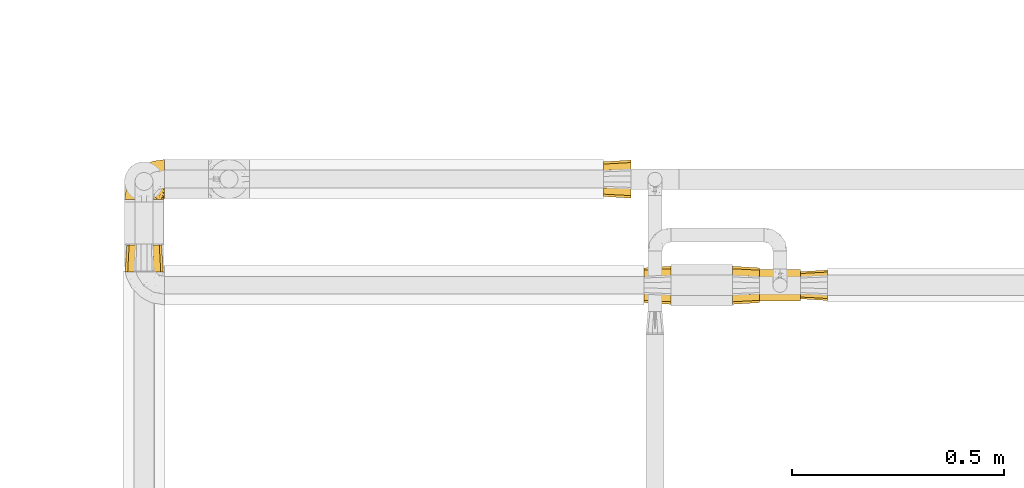
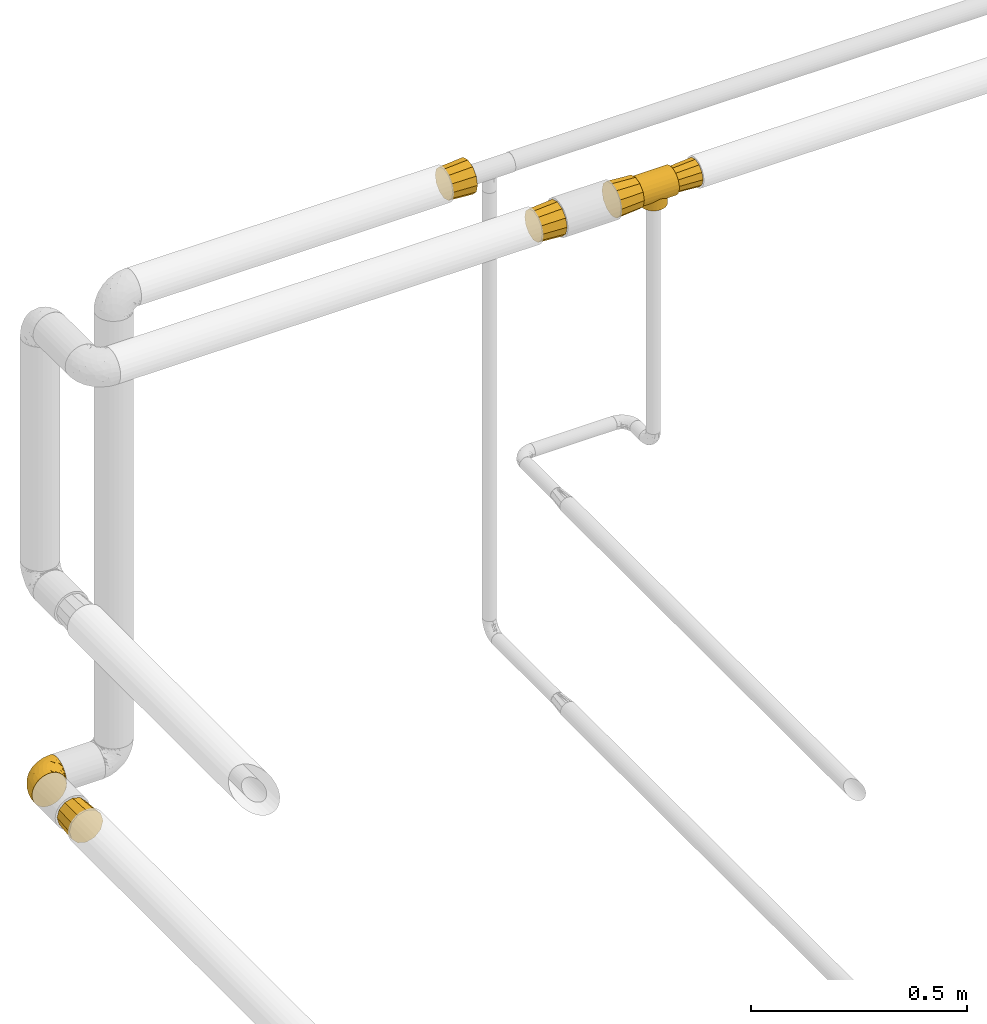
# One storey, part 133 of 827: 7 coverings.
"""IFC2X3 building model written with IfcOpenShell, lengths in millimetres."""

from ifc_helpers import new_model, entity, si_unit, converted_unit, derived_unit, direction, frame, origin, place, context, subcontext, project, spatial, faceted_brep, element, save


model = new_model("IFC2X3")

# Units and contexts
model_context = context("Model", 3, precision=0.01, world=origin(), true_north=direction((6.12303176911189e-17, 1.0)))
body_context = subcontext(model_context, "Body", "Model", "MODEL_VIEW")
ifc_project = project(units=[si_unit("LENGTHUNIT", "METRE", prefix="MILLI"), si_unit("AREAUNIT", "SQUARE_METRE"), si_unit("VOLUMEUNIT", "CUBIC_METRE"), converted_unit("PLANEANGLEUNIT", "DEGREE", entity("IfcRatioMeasure", 0.0174532925199433), si_unit("PLANEANGLEUNIT", "RADIAN"), dimensions=[0, 0, 0, 0, 0, 0, 0]), si_unit("MASSUNIT", "GRAM", prefix="KILO"), derived_unit("MASSDENSITYUNIT", [(si_unit("MASSUNIT", "GRAM", prefix="KILO"), 1), (si_unit("LENGTHUNIT", "METRE"), -3)]), derived_unit("MOMENTOFINERTIAUNIT", [(si_unit("LENGTHUNIT", "METRE"), 4)]), si_unit("TIMEUNIT", "SECOND"), si_unit("FREQUENCYUNIT", "HERTZ"), si_unit("THERMODYNAMICTEMPERATUREUNIT", "DEGREE_CELSIUS"), derived_unit("THERMALTRANSMITTANCEUNIT", [(si_unit("MASSUNIT", "GRAM", prefix="KILO"), 1), (si_unit("THERMODYNAMICTEMPERATUREUNIT", "KELVIN"), -1), (si_unit("TIMEUNIT", "SECOND"), -3)]), derived_unit("VOLUMETRICFLOWRATEUNIT", [(si_unit("LENGTHUNIT", "METRE"), 3), (si_unit("TIMEUNIT", "SECOND"), -1)]), derived_unit("MASSFLOWRATEUNIT", [(si_unit("MASSUNIT", "GRAM", prefix="KILO"), 1), (si_unit("TIMEUNIT", "SECOND"), -1)]), derived_unit("ROTATIONALFREQUENCYUNIT", [(si_unit("TIMEUNIT", "SECOND"), -1)]), si_unit("ELECTRICCURRENTUNIT", "AMPERE"), si_unit("ELECTRICVOLTAGEUNIT", "VOLT"), si_unit("POWERUNIT", "WATT"), si_unit("FORCEUNIT", "NEWTON", prefix="KILO"), si_unit("ILLUMINANCEUNIT", "LUX"), si_unit("LUMINOUSFLUXUNIT", "LUMEN"), si_unit("LUMINOUSINTENSITYUNIT", "CANDELA"), derived_unit("USERDEFINED", [(si_unit("MASSUNIT", "GRAM", prefix="KILO"), -1), (si_unit("LENGTHUNIT", "METRE"), -2), (si_unit("TIMEUNIT", "SECOND"), 3), (si_unit("LUMINOUSFLUXUNIT", "LUMEN"), 1)]), derived_unit("LINEARVELOCITYUNIT", [(si_unit("LENGTHUNIT", "METRE"), 1), (si_unit("TIMEUNIT", "SECOND"), -1)]), si_unit("PRESSUREUNIT", "PASCAL"), derived_unit("USERDEFINED", [(si_unit("LENGTHUNIT", "METRE"), -2), (si_unit("MASSUNIT", "GRAM", prefix="KILO"), 1), (si_unit("TIMEUNIT", "SECOND"), -2)]), derived_unit("LINEARFORCEUNIT", [(si_unit("MASSUNIT", "GRAM", prefix="KILO"), 1), (si_unit("LENGTHUNIT", "METRE"), 1), (si_unit("TIMEUNIT", "SECOND"), -2), (si_unit("LENGTHUNIT", "METRE"), -1)]), derived_unit("PLANARFORCEUNIT", [(si_unit("MASSUNIT", "GRAM", prefix="KILO"), 1), (si_unit("LENGTHUNIT", "METRE"), 1), (si_unit("TIMEUNIT", "SECOND"), -2), (si_unit("LENGTHUNIT", "METRE"), -2)])], contexts=[model_context])

# Site, building, storey
site_placement = place(None, origin())
site = spatial("IfcSite", under=ifc_project, at=site_placement, CompositionType="ELEMENT")
building_placement = place(site_placement, origin())
building = spatial("IfcBuilding", under=site, at=building_placement, CompositionType="ELEMENT")
storey_placement = place(building_placement, frame((0.0, 0.0, 28200.0)))
storey = spatial("IfcBuildingStorey", under=building, at=storey_placement, Name="08", CompositionType="ELEMENT", Elevation=28200.0)

# Coverings
covering_1_placement = place(storey_placement, frame((13457.95, 18724.18, 2952.0)))
element("IfcCovering", 1, at=covering_1_placement, inside=storey, Name=":ADSK_", ObjectType=":ADSK_", PredefinedType="INSULATION", context=body_context, shape_type="Brep", body=[
    faceted_brep([(0.0, 6.58, 66.6), (0.0, 12.49, 74.3), (0.0, 20.2, 80.22), (0.0, 29.17, 83.93), (0.0, 38.8, 85.2), (0.0, 48.42, 83.93), (0.0, 57.4, 80.22), (0.0, 65.1, 74.3), (0.0, 71.01, 66.6), (0.0, 74.73, 57.63), (0.0, 76.0, 48.0), (0.0, 74.73, 38.37), (0.0, 71.01, 29.4), (0.0, 68.06, 25.55), (0.0, 65.1, 21.7), (0.0, 61.25, 18.74), (0.0, 57.4, 15.78), (0.0, 52.91, 13.93), (0.0, 50.67, 13.0), (0.0, 48.42, 12.07), (0.0, 46.02, 11.75), (0.0, 43.61, 11.43), (0.0, 38.8, 10.8), (0.0, 33.98, 11.43), (0.0, 31.57, 11.75), (0.0, 29.17, 12.07), (0.0, 26.92, 13.0), (0.0, 24.68, 13.93), (0.0, 20.2, 15.78), (0.0, 16.34, 18.74), (0.0, 12.49, 21.7), (0.0, 9.54, 25.55), (0.0, 6.58, 29.4), (0.0, 2.86, 38.37), (0.0, 1.6, 48.0), (0.0, 2.86, 57.63), (96.0, 74.73, 57.63), (96.0, 71.01, 66.6), (96.0, 65.1, 74.3), (96.0, 57.4, 80.22), (96.0, 48.42, 83.93), (96.0, 38.8, 85.2), (96.0, 29.17, 83.93), (96.0, 20.2, 80.22), (96.0, 12.49, 74.3), (96.0, 6.58, 66.6), (96.0, 2.86, 57.63), (96.0, 1.6, 48.0), (96.0, 2.86, 38.37), (96.0, 6.58, 29.4), (96.0, 9.54, 25.55), (96.0, 12.49, 21.7), (96.0, 16.34, 18.74), (96.0, 20.2, 15.78), (96.0, 24.68, 13.93), (96.0, 26.92, 13.0), (96.0, 29.17, 12.07), (96.0, 31.57, 11.75), (96.0, 33.98, 11.43), (96.0, 38.8, 10.8), (96.0, 43.61, 11.43), (96.0, 46.02, 11.75), (96.0, 48.42, 12.07), (96.0, 50.67, 13.0), (96.0, 52.91, 13.93), (96.0, 57.4, 15.78), (96.0, 61.25, 18.74), (96.0, 65.1, 21.7), (96.0, 68.06, 25.55), (96.0, 71.01, 29.4), (96.0, 74.73, 38.37), (96.0, 76.0, 48.0), (48.0, 71.65, 30.54), (68.25, 64.67, 21.27), (62.44, 68.3, 25.35), (17.44, 50.24, 12.8), (18.78, 53.81, 13.96), (55.72, 70.72, 28.91), (33.56, 68.3, 25.35), (16.11, 46.67, 11.64), (15.63, 42.73, 11.22), (40.28, 70.72, 28.91), (15.15, 38.8, 10.8), (80.85, 38.8, 10.8), (80.37, 42.73, 11.22), (27.75, 64.67, 21.27), (22.78, 59.84, 17.33), (73.22, 59.84, 17.33), (77.22, 53.81, 13.96), (75.22, 56.83, 15.65), (78.56, 50.24, 12.8), (79.89, 46.67, 11.64), (20.78, 56.83, 15.65), (80.37, 34.86, 11.22), (79.89, 30.92, 11.64), (16.11, 30.92, 11.64), (77.22, 23.78, 13.96), (73.22, 17.75, 17.33), (75.22, 20.77, 15.65), (68.25, 12.93, 21.27), (78.56, 27.35, 12.8), (15.63, 34.86, 11.22), (62.44, 9.29, 25.35), (20.78, 20.77, 15.65), (22.78, 17.75, 17.33), (18.78, 23.78, 13.96), (17.44, 27.35, 12.8), (48.0, 5.95, 30.54), (55.72, 6.87, 28.91), (33.56, 9.29, 25.35), (27.75, 12.93, 21.27), (40.28, 6.87, 28.91), (71.23, 62.02, 0.0), (76.45, 55.22, 0.0), (79.73, 47.3, 0.0), (80.85, 38.8, 0.0), (79.73, 30.29, 0.0), (76.45, 22.37, 0.0), (71.23, 15.57, 0.0), (64.42, 10.35, 0.0), (56.5, 7.06, 0.0), (48.0, 5.95, 0.0), (39.5, 7.06, 0.0), (31.57, 10.35, 0.0), (24.77, 15.57, 0.0), (19.55, 22.37, 0.0), (16.27, 30.29, 0.0), (15.15, 38.8, 0.0), (16.27, 47.3, 0.0), (19.55, 55.22, 0.0), (24.77, 62.02, 0.0), (31.57, 67.24, 0.0), (39.5, 70.53, 0.0), (48.0, 71.65, 0.0), (56.5, 70.53, 0.0), (64.42, 67.24, 0.0)], [[[0, 1, 2, 3, 4, 5, 6, 7, 8, 9, 10, 11, 12, 13, 14, 15, 16, 17, 18, 19, 20, 21, 22, 23, 24, 25, 26, 27, 28, 29, 30, 31, 32, 33, 34, 35]], [[36, 37, 38, 39, 40, 41, 42, 43, 44, 45, 46, 47, 48, 49, 50, 51, 52, 53, 54, 55, 56, 57, 58, 59, 60, 61, 62, 63, 64, 65, 66, 67, 68, 69, 70, 71]], [[39, 38, 7, 6]], [[4, 41, 40, 5]], [[40, 39, 6, 5]], [[8, 37, 36, 9]], [[9, 36, 71, 10]], [[7, 38, 37, 8]], [[70, 11, 10, 71]], [[69, 72, 70]], [[67, 73, 74]], [[67, 66, 73]], [[75, 17, 76]], [[77, 69, 74]], [[78, 14, 13, 12]], [[74, 69, 68, 67]], [[77, 72, 69]], [[11, 70, 72]], [[11, 72, 12]], [[21, 79, 80]], [[81, 78, 12]], [[22, 80, 82]], [[83, 84, 59]], [[14, 78, 85]], [[81, 12, 72]], [[86, 16, 15]], [[59, 84, 60]], [[75, 19, 18, 17]], [[87, 65, 88, 89]], [[73, 66, 87]], [[63, 62, 90, 64]], [[91, 62, 61, 60]], [[91, 60, 84]], [[90, 88, 64]], [[15, 14, 85]], [[88, 65, 64]], [[16, 76, 17]], [[76, 16, 86, 92]], [[62, 91, 90]], [[15, 85, 86]], [[22, 21, 80]], [[20, 19, 79, 21]], [[79, 19, 75]], [[87, 66, 65]], [[58, 93, 59]], [[94, 58, 57, 56]], [[95, 25, 24, 23]], [[54, 53, 96]], [[97, 53, 52]], [[98, 96, 53, 97]], [[51, 99, 52]], [[56, 100, 94]], [[59, 93, 83]], [[101, 22, 82]], [[95, 23, 101]], [[102, 51, 50, 49]], [[100, 56, 55, 54]], [[103, 104, 28, 105]], [[100, 54, 96]], [[22, 101, 23]], [[25, 106, 27, 26]], [[104, 29, 28]], [[27, 106, 105]], [[58, 94, 93]], [[99, 51, 102]], [[99, 97, 52]], [[25, 95, 106]], [[107, 49, 48]], [[107, 108, 49]], [[49, 108, 102]], [[48, 47, 34, 33]], [[105, 28, 27]], [[30, 109, 32, 31]], [[110, 29, 104]], [[30, 29, 110]], [[30, 110, 109]], [[109, 111, 32]], [[32, 107, 33]], [[107, 32, 111]], [[33, 107, 48]], [[35, 46, 45, 0]], [[0, 45, 44, 1]], [[47, 46, 35, 34]], [[2, 43, 42, 3]], [[3, 42, 41, 4]], [[1, 44, 43, 2]], [[112, 113, 114, 115, 116, 117, 118, 119, 120, 121, 122, 123, 124, 125, 126, 127, 128, 129, 130, 131, 132, 133, 134, 135]], [[91, 115, 114]], [[88, 114, 113]], [[115, 91, 84, 83]], [[113, 87, 89, 88]], [[114, 88, 90, 91]], [[113, 112, 87]], [[112, 135, 73]], [[135, 134, 74]], [[77, 134, 133]], [[73, 135, 74]], [[77, 74, 134]], [[72, 77, 133]], [[112, 73, 87]], [[81, 133, 132]], [[78, 132, 131]], [[72, 133, 81]], [[81, 132, 78]], [[131, 85, 78]], [[131, 130, 85]], [[130, 129, 86]], [[129, 128, 76]], [[79, 128, 127]], [[129, 76, 92, 86]], [[127, 82, 80, 79]], [[128, 79, 75, 76]], [[130, 86, 85]], [[95, 127, 126]], [[105, 126, 125]], [[127, 95, 101, 82]], [[125, 104, 103, 105]], [[126, 105, 106, 95]], [[125, 124, 104]], [[110, 124, 123]], [[122, 121, 111]], [[109, 123, 122]], [[110, 123, 109]], [[111, 109, 122]], [[107, 111, 121]], [[124, 110, 104]], [[108, 121, 120]], [[102, 120, 119]], [[107, 121, 108]], [[108, 120, 102]], [[119, 99, 102]], [[119, 118, 99]], [[97, 118, 117]], [[117, 116, 96]], [[115, 94, 116]], [[117, 96, 98, 97]], [[115, 83, 93, 94]], [[116, 94, 100, 96]], [[118, 97, 99]]]),
])
covering_2_placement = place(storey_placement, frame((13553.95, 18725.38, 2962.4)))
element("IfcCovering", 2, at=covering_2_placement, inside=storey, Name=":ADSK_", ObjectType=":ADSK_", PredefinedType="INSULATION", context=body_context, shape_type="Brep", body=[
    faceted_brep([(64.0, 55.6, 68.77), (64.0, 47.12, 71.04), (64.0, 37.6, 73.6), (64.0, 28.07, 71.04), (64.0, 19.6, 68.77), (64.0, 13.01, 62.18), (64.0, 6.42, 55.6), (64.0, 4.15, 47.12), (64.0, 1.6, 37.6), (64.0, 4.15, 28.07), (64.0, 6.42, 19.6), (64.0, 13.01, 13.01), (64.0, 19.6, 6.42), (64.0, 28.07, 4.15), (64.0, 37.6, 1.6), (64.0, 47.12, 4.15), (64.0, 55.6, 6.42), (64.0, 62.18, 13.01), (64.0, 68.77, 19.6), (64.0, 71.04, 28.07), (64.0, 73.6, 37.6), (64.0, 71.04, 47.12), (64.0, 68.77, 55.6), (64.0, 62.18, 62.18), (0.0, 69.6, 37.6), (0.0, 67.45, 29.6), (0.0, 65.31, 21.6), (0.0, 59.45, 15.74), (0.0, 53.6, 9.88), (0.0, 45.6, 7.74), (0.0, 37.6, 5.6), (0.0, 29.6, 7.74), (0.0, 21.6, 9.88), (0.0, 15.74, 15.74), (0.0, 9.88, 21.6), (0.0, 7.74, 29.6), (0.0, 5.6, 37.6), (0.0, 7.74, 45.6), (0.0, 9.88, 53.6), (0.0, 15.74, 59.45), (0.0, 21.6, 65.31), (0.0, 29.6, 67.45), (0.0, 37.6, 69.6), (0.0, 45.6, 67.45), (0.0, 53.6, 65.31), (0.0, 59.45, 59.45), (0.0, 65.31, 53.6), (0.0, 67.45, 45.6)], [[[0, 1, 2, 3, 4, 5, 6, 7, 8, 9, 10, 11, 12, 13, 14, 15, 16, 17, 18, 19, 20, 21, 22, 23]], [[24, 25, 26, 27, 28, 29, 30, 31, 32, 33, 34, 35, 36, 37, 38, 39, 40, 41, 42, 43, 44, 45, 46, 47]], [[34, 10, 9, 8, 36, 35]], [[11, 10, 34, 33, 32, 12]], [[31, 30, 14, 13, 12, 32]], [[28, 16, 15, 14, 30, 29]], [[17, 16, 28, 27, 26, 18]], [[25, 24, 20, 19, 18, 26]], [[46, 22, 21, 20, 24, 47]], [[23, 22, 46, 45, 44, 0]], [[43, 42, 2, 1, 0, 44]], [[40, 4, 3, 2, 42, 41]], [[5, 4, 40, 39, 38, 6]], [[37, 36, 8, 7, 6, 38]]]),
])
covering_3_placement = place(storey_placement, frame((13393.95, 18716.38, 2953.4)))
element("IfcCovering", 3, at=covering_3_placement, inside=storey, Name=":ADSK_", ObjectType=":ADSK_", PredefinedType="INSULATION", context=body_context, shape_type="Brep", body=[
    faceted_brep([(0.0, 91.6, 46.6), (0.0, 88.01, 33.21), (0.0, 85.57, 24.1), (0.0, 77.33, 15.86), (0.0, 69.1, 7.62), (0.0, 59.99, 5.18), (0.0, 46.6, 1.6), (0.0, 33.21, 5.18), (0.0, 24.1, 7.62), (0.0, 15.86, 15.86), (0.0, 7.62, 24.1), (0.0, 5.18, 33.21), (0.0, 1.6, 46.6), (0.0, 5.18, 59.99), (0.0, 7.62, 69.1), (0.0, 15.86, 77.33), (0.0, 24.1, 85.57), (0.0, 33.21, 88.01), (0.0, 46.6, 91.6), (0.0, 59.99, 88.01), (0.0, 69.1, 85.57), (0.0, 77.33, 77.33), (0.0, 85.57, 69.1), (0.0, 88.01, 59.99), (64.0, 67.1, 82.1), (64.0, 56.85, 84.85), (64.0, 46.6, 87.6), (64.0, 36.35, 84.85), (64.0, 26.1, 82.1), (64.0, 18.59, 74.6), (64.0, 11.09, 67.1), (64.0, 8.34, 56.85), (64.0, 5.6, 46.6), (64.0, 8.34, 36.35), (64.0, 11.09, 26.1), (64.0, 18.59, 18.59), (64.0, 26.1, 11.09), (64.0, 36.35, 8.34), (64.0, 46.6, 5.6), (64.0, 56.85, 8.34), (64.0, 67.1, 11.09), (64.0, 74.6, 18.59), (64.0, 82.1, 26.1), (64.0, 84.85, 36.35), (64.0, 87.6, 46.6), (64.0, 84.85, 56.85), (64.0, 82.1, 67.1), (64.0, 74.6, 74.6)], [[[0, 1, 2, 3, 4, 5, 6, 7, 8, 9, 10, 11, 12, 13, 14, 15, 16, 17, 18, 19, 20, 21, 22, 23]], [[24, 25, 26, 27, 28, 29, 30, 31, 32, 33, 34, 35, 36, 37, 38, 39, 40, 41, 42, 43, 44, 45, 46, 47]], [[30, 14, 13, 12, 32, 31]], [[15, 14, 30, 29, 28, 16]], [[27, 26, 18, 17, 16, 28]], [[24, 20, 19, 18, 26, 25]], [[21, 20, 24, 47, 46, 22]], [[45, 44, 0, 23, 22, 46]], [[42, 2, 1, 0, 44, 43]], [[3, 2, 42, 41, 40, 4]], [[39, 38, 6, 5, 4, 40]], [[36, 8, 7, 6, 38, 37]], [[9, 8, 36, 35, 34, 10]], [[33, 32, 12, 11, 10, 34]]]),
])
covering_4_placement = place(storey_placement, frame((13184.89, 18716.38, 2953.4)))
element("IfcCovering", 4, at=covering_4_placement, inside=storey, Name=":ADSK_", ObjectType=":ADSK_", PredefinedType="INSULATION", context=body_context, shape_type="Brep", body=[
    faceted_brep([(0.0, 74.6, 74.6), (0.0, 82.1, 67.1), (0.0, 84.85, 56.85), (0.0, 87.6, 46.6), (0.0, 84.85, 36.35), (0.0, 82.1, 26.1), (0.0, 74.6, 18.59), (0.0, 67.1, 11.09), (0.0, 56.85, 8.34), (0.0, 46.6, 5.6), (0.0, 36.35, 8.34), (0.0, 26.1, 11.09), (0.0, 18.59, 18.59), (0.0, 11.09, 26.1), (0.0, 8.34, 36.35), (0.0, 5.6, 46.6), (0.0, 8.34, 56.85), (0.0, 11.09, 67.1), (0.0, 18.59, 74.6), (0.0, 26.1, 82.1), (0.0, 36.35, 84.85), (0.0, 46.6, 87.6), (0.0, 56.85, 84.85), (0.0, 67.1, 82.1), (64.0, 33.21, 88.01), (64.0, 24.1, 85.57), (64.0, 15.86, 77.33), (64.0, 7.62, 69.1), (64.0, 5.18, 59.99), (64.0, 1.6, 46.6), (64.0, 5.18, 33.21), (64.0, 7.62, 24.1), (64.0, 15.86, 15.86), (64.0, 24.1, 7.62), (64.0, 33.21, 5.18), (64.0, 46.6, 1.6), (64.0, 59.99, 5.18), (64.0, 69.1, 7.62), (64.0, 77.33, 15.86), (64.0, 85.57, 24.1), (64.0, 88.01, 33.21), (64.0, 91.6, 46.6), (64.0, 88.01, 59.99), (64.0, 85.57, 69.1), (64.0, 77.33, 77.33), (64.0, 69.1, 85.57), (64.0, 59.99, 88.01), (64.0, 46.6, 91.6)], [[[0, 1, 2, 3, 4, 5, 6, 7, 8, 9, 10, 11, 12, 13, 14, 15, 16, 17, 18, 19, 20, 21, 22, 23]], [[24, 25, 26, 27, 28, 29, 30, 31, 32, 33, 34, 35, 36, 37, 38, 39, 40, 41, 42, 43, 44, 45, 46, 47]], [[7, 37, 36, 35, 9, 8]], [[39, 38, 37, 7, 6, 5]], [[4, 3, 41, 40, 39, 5]], [[13, 31, 30, 29, 15, 14]], [[33, 32, 31, 13, 12, 11]], [[10, 9, 35, 34, 33, 11]], [[19, 25, 24, 47, 21, 20]], [[27, 26, 25, 19, 18, 17]], [[16, 15, 29, 28, 27, 17]], [[1, 43, 42, 41, 3, 2]], [[45, 44, 43, 1, 0, 23]], [[22, 21, 47, 46, 45, 23]]]),
])
covering_5_placement = place(storey_placement, frame((11958.15, 18963.87, 1646.47)))
element("IfcCovering", 5, at=covering_5_placement, inside=storey, Name=":ADSK_", ObjectType=":ADSK_", PredefinedType="INSULATION", context=body_context, shape_type="Brep", body=[
    faceted_brep([(18.98, 1.6, 83.91), (11.67, 1.6, 76.59), (6.17, 1.6, 67.83), (2.75, 1.6, 58.07), (1.6, 1.6, 47.8), (2.75, 1.6, 37.51), (6.17, 1.6, 27.74), (11.68, 1.6, 18.98), (19.0, 1.6, 11.67), (27.76, 1.6, 6.17), (37.52, 1.6, 2.75), (47.8, 1.6, 1.6), (51.94, 1.6, 2.06), (55.01, 1.6, 2.41), (58.08, 1.6, 2.75), (62.96, 1.6, 4.46), (67.85, 1.6, 6.17), (72.23, 1.6, 8.93), (76.61, 1.6, 11.68), (80.26, 1.6, 15.34), (83.92, 1.6, 19.0), (89.42, 1.6, 27.76), (91.13, 1.6, 32.64), (92.84, 1.6, 37.52), (94.0, 1.6, 47.8), (92.84, 1.6, 58.08), (91.13, 1.6, 62.96), (89.42, 1.6, 67.85), (83.91, 1.6, 76.61), (80.25, 1.6, 80.26), (76.59, 1.6, 83.92), (72.21, 1.6, 86.67), (67.83, 1.6, 89.42), (62.95, 1.6, 91.13), (58.07, 1.6, 92.84), (55.0, 1.6, 93.18), (51.94, 1.6, 93.53), (47.8, 1.6, 94.0), (37.51, 1.6, 92.84), (27.74, 1.6, 89.42), (95.8, 3.4, 47.8), (95.8, 4.97, 35.84), (95.8, 9.58, 24.7), (95.8, 13.26, 19.91), (95.8, 16.93, 15.13), (95.8, 21.71, 11.46), (95.8, 26.5, 7.78), (95.8, 32.07, 5.48), (95.8, 37.64, 3.17), (95.8, 41.25, 2.69), (95.8, 43.34, 2.42), (95.8, 45.42, 2.14), (95.8, 49.6, 1.6), (95.8, 61.55, 3.17), (95.8, 72.7, 7.78), (95.8, 82.26, 15.13), (95.8, 89.61, 24.7), (95.8, 94.22, 35.84), (95.8, 95.8, 47.8), (95.8, 94.22, 59.75), (95.8, 89.61, 70.9), (95.8, 82.26, 80.46), (95.8, 72.7, 87.81), (95.8, 61.55, 92.42), (95.8, 49.6, 94.0), (95.8, 45.42, 93.45), (95.8, 41.25, 92.9), (95.8, 37.64, 92.42), (95.8, 32.07, 90.11), (95.8, 26.5, 87.81), (95.8, 21.71, 84.13), (95.8, 16.93, 80.46), (95.8, 13.26, 75.68), (95.8, 9.58, 70.9), (95.8, 4.97, 59.75), (60.58, 81.55, 71.98), (74.11, 90.4, 63.6), (51.59, 83.0, 59.72), (66.69, 91.18, 47.8), (76.19, 93.13, 55.16), (84.43, 94.0, 47.8), (31.2, 66.19, 63.76), (42.88, 70.92, 72.22), (79.41, 85.95, 74.18), (60.7, 49.74, 92.52), (61.85, 35.54, 94.0), (65.75, 38.14, 94.0), (69.64, 40.74, 94.0), (73.53, 43.34, 94.0), (77.43, 45.94, 94.0), (74.59, 77.59, 82.14), (54.72, 71.17, 80.34), (64.18, 65.81, 87.52), (37.94, 59.03, 79.59), (25.89, 45.85, 78.25), (34.73, 45.79, 85.01), (42.89, 41.42, 90.25), (49.83, 34.51, 93.2), (48.58, 56.04, 87.23), (22.41, 15.15, 85.55), (78.69, 56.51, 93.0), (81.64, 68.39, 89.31), (6.22, 23.33, 61.31), (12.11, 42.86, 56.86), (14.81, 39.42, 68.34), (21.61, 53.58, 65.71), (22.41, 59.17, 56.99), (30.12, 59.06, 72.15), (10.01, 22.63, 70.34), (15.36, 20.55, 78.36), (3.39, 12.96, 47.8), (19.59, 56.96, 47.8), (30.01, 67.38, 47.8), (41.19, 18.72, 93.06), (48.54, 5.33, 94.0), (49.28, 9.07, 94.0), (49.82, 11.79, 94.0), (50.37, 14.51, 94.0), (50.91, 17.24, 94.0), (51.45, 19.96, 94.0), (31.61, 21.03, 89.88), (80.15, 46.48, 94.0), (82.88, 47.03, 94.0), (85.6, 47.57, 94.0), (88.32, 48.11, 94.0), (90.19, 48.48, 94.0), (92.06, 48.85, 94.0), (6.21, 30.7, 47.8), (54.05, 23.86, 94.0), (56.65, 27.75, 94.0), (59.25, 31.64, 94.0), (24.66, 31.26, 83.7), (40.43, 77.8, 47.8), (35.17, 72.75, 55.9), (12.9, 43.83, 47.8), (53.56, 84.49, 47.8), (85.34, 14.58, 81.75), (78.44, 16.17, 86.43), (84.37, 10.82, 79.8), (89.05, 4.64, 69.84), (82.76, 7.71, 79.5), (86.31, 25.13, 88.08), (83.73, 32.66, 91.6), (77.31, 34.94, 92.93), (87.78, 36.76, 92.43), (87.91, 40.48, 93.24), (81.29, 39.25, 93.36), (93.97, 3.69, 57.25), (70.76, 13.99, 89.41), (63.67, 21.85, 92.89), (62.62, 17.93, 92.66), (90.64, 15.11, 79.58), (84.08, 21.14, 86.51), (76.28, 12.7, 86.29), (77.45, 7.21, 83.91), (91.35, 10.45, 73.94), (88.72, 32.27, 90.94), (71.28, 25.68, 91.94), (68.09, 22.18, 91.98), (91.07, 18.79, 82.79), (57.47, 10.12, 93.16), (70.34, 9.47, 88.76), (62.99, 11.29, 91.89), (94.52, 2.87, 47.8), (76.47, 31.16, 92.22), (69.96, 6.31, 88.56), (89.86, 25.62, 87.72), (78.94, 21.18, 88.33), (73.51, 28.81, 92.18), (89.62, 7.45, 71.78), (84.09, 21.14, 9.09), (86.3, 25.13, 7.51), (91.06, 18.79, 12.8), (88.32, 48.11, 1.6), (92.06, 48.85, 1.6), (82.88, 47.03, 1.6), (85.6, 47.57, 1.6), (93.97, 3.69, 38.35), (89.63, 7.44, 23.84), (50.37, 14.51, 1.6), (49.82, 11.79, 1.6), (48.54, 5.33, 1.6), (49.28, 9.07, 1.6), (82.77, 7.71, 16.1), (70.36, 9.47, 6.84), (77.31, 34.94, 2.66), (76.47, 31.16, 3.37), (69.64, 40.74, 1.6), (65.75, 38.14, 1.6), (87.78, 36.76, 3.16), (87.91, 40.48, 2.35), (89.06, 4.63, 25.77), (90.65, 15.11, 16.02), (85.35, 14.58, 13.85), (73.53, 43.34, 1.6), (77.43, 45.94, 1.6), (81.29, 39.25, 2.23), (77.46, 7.21, 11.69), (76.29, 12.69, 9.31), (57.47, 10.14, 2.43), (63.71, 21.81, 2.71), (68.11, 22.19, 3.61), (70.77, 14.0, 6.18), (71.31, 25.69, 3.66), (78.46, 16.17, 9.17), (69.52, 6.66, 6.77), (62.64, 17.92, 2.93), (91.35, 10.45, 21.66), (59.25, 31.64, 1.6), (84.6, 10.64, 16.09), (62.98, 11.31, 3.7), (51.45, 19.96, 1.6), (54.05, 23.86, 1.6), (56.65, 27.75, 1.6), (83.73, 32.66, 3.99), (80.15, 46.48, 1.6), (88.72, 32.27, 4.65), (61.85, 35.54, 1.6), (73.56, 28.77, 3.43), (78.96, 21.17, 7.27), (91.36, 23.36, 9.46), (50.91, 17.24, 1.6), (62.87, 47.58, 2.4), (76.19, 93.13, 40.43), (73.57, 77.44, 13.57), (56.07, 66.78, 11.3), (49.77, 71.68, 18.65), (44.73, 74.96, 27.26), (60.58, 81.55, 23.61), (47.64, 36.7, 3.07), (78.32, 56.9, 2.69), (51.59, 83.0, 35.87), (74.11, 90.4, 31.99), (76.04, 67.83, 6.71), (79.41, 85.95, 21.41), (14.82, 39.41, 27.24), (6.22, 23.33, 34.26), (12.12, 42.87, 38.73), (23.51, 53.92, 26.97), (31.2, 66.19, 31.83), (34.96, 64.12, 23.4), (33.86, 33.13, 6.91), (38.94, 23.1, 3.4), (30.23, 16.98, 5.84), (35.17, 72.75, 39.69), (15.85, 23.77, 17.6), (22.59, 18.41, 10.38), (21.56, 43.7, 20.6), (55.94, 54.53, 5.36), (20.67, 55.72, 35.73), (9.19, 17.73, 24.84), (25.79, 38.98, 13.87), (41.16, 50.28, 9.06), (37.95, 59.02, 15.99)], [[[0, 1, 2, 3, 4, 5, 6, 7, 8, 9, 10, 11, 12, 13, 14, 15, 16, 17, 18, 19, 20, 21, 22, 23, 24, 25, 26, 27, 28, 29, 30, 31, 32, 33, 34, 35, 36, 37, 38, 39]], [[40, 41, 42, 43, 44, 45, 46, 47, 48, 49, 50, 51, 52, 53, 54, 55, 56, 57, 58, 59, 60, 61, 62, 63, 64, 65, 66, 67, 68, 69, 70, 71, 72, 73, 74]], [[75, 76, 77]], [[78, 79, 80]], [[77, 81, 82]], [[76, 75, 83]], [[84, 85, 86, 87, 88, 89]], [[90, 91, 92]], [[76, 60, 59]], [[93, 94, 95]], [[90, 62, 61]], [[83, 61, 60]], [[96, 97, 84]], [[98, 93, 95]], [[0, 39, 99]], [[100, 84, 89]], [[62, 101, 63]], [[2, 102, 3]], [[92, 84, 100]], [[103, 102, 104]], [[103, 105, 106]], [[93, 107, 94]], [[1, 108, 2]], [[92, 101, 90]], [[108, 1, 109]], [[102, 110, 3]], [[93, 82, 107]], [[102, 108, 104]], [[111, 106, 112]], [[109, 0, 99]], [[113, 37, 114, 115, 116, 117, 118, 119]], [[120, 38, 113]], [[100, 89, 121, 122, 123, 124, 125, 126, 64]], [[127, 102, 103]], [[97, 119, 128, 129, 130, 85]], [[99, 120, 131]], [[132, 133, 77]], [[59, 80, 79]], [[1, 0, 109]], [[98, 84, 92]], [[94, 109, 131]], [[120, 39, 38]], [[93, 91, 82]], [[104, 94, 105]], [[97, 113, 119]], [[95, 120, 96]], [[83, 90, 61]], [[91, 93, 98]], [[64, 63, 100]], [[100, 63, 101]], [[77, 76, 79]], [[133, 106, 81]], [[84, 97, 85]], [[113, 96, 120]], [[113, 97, 96]], [[37, 113, 38]], [[110, 102, 127]], [[110, 4, 3]], [[103, 111, 134, 127]], [[90, 75, 91]], [[82, 81, 107]], [[91, 75, 82]], [[77, 82, 75]], [[76, 83, 60]], [[90, 83, 75]], [[105, 107, 81]], [[94, 131, 95]], [[105, 94, 107]], [[109, 94, 104]], [[120, 95, 131]], [[98, 95, 96]], [[84, 98, 96]], [[98, 92, 91]], [[106, 105, 81]], [[103, 104, 105]], [[112, 106, 133]], [[103, 106, 111]], [[112, 133, 132]], [[81, 77, 133]], [[77, 78, 135, 132]], [[120, 99, 39]], [[109, 99, 131]], [[59, 58, 80]], [[59, 79, 76]], [[90, 101, 62]], [[100, 101, 92]], [[2, 108, 102]], [[109, 104, 108]], [[78, 77, 79]], [[136, 137, 138]], [[27, 139, 140]], [[141, 142, 143]], [[144, 145, 121]], [[146, 89, 88]], [[147, 139, 25]], [[148, 149, 150]], [[136, 151, 152]], [[147, 40, 74]], [[24, 147, 25]], [[140, 153, 154]], [[33, 116, 34]], [[73, 151, 155]], [[114, 37, 36, 35, 34, 116, 115]], [[146, 156, 144]], [[157, 85, 130]], [[158, 149, 148]], [[151, 159, 152]], [[117, 33, 160]], [[29, 154, 161]], [[155, 74, 73]], [[162, 128, 119]], [[66, 65, 64, 126, 125, 124, 123, 122, 67]], [[163, 147, 24]], [[27, 140, 28]], [[149, 129, 150]], [[139, 27, 26, 25]], [[68, 144, 69]], [[129, 128, 150]], [[164, 87, 86]], [[130, 129, 149]], [[122, 145, 67]], [[154, 153, 148]], [[162, 119, 160]], [[165, 30, 161]], [[150, 161, 148]], [[128, 162, 150]], [[30, 165, 31]], [[145, 144, 68]], [[89, 146, 144]], [[87, 164, 143]], [[166, 156, 142]], [[88, 87, 143]], [[162, 161, 150]], [[161, 30, 29]], [[154, 29, 28]], [[140, 154, 28]], [[161, 154, 148]], [[140, 137, 153]], [[158, 148, 153]], [[157, 130, 158]], [[153, 137, 158]], [[158, 137, 157]], [[167, 137, 136]], [[168, 85, 157]], [[152, 168, 167]], [[167, 168, 157]], [[164, 152, 141]], [[151, 73, 72]], [[159, 72, 71]], [[88, 142, 146]], [[144, 156, 69]], [[146, 142, 156]], [[70, 166, 71]], [[142, 141, 166]], [[70, 69, 156]], [[141, 159, 71]], [[167, 136, 152]], [[138, 137, 140]], [[155, 136, 169]], [[136, 155, 151]], [[74, 155, 169]], [[152, 159, 141]], [[151, 72, 159]], [[168, 152, 164]], [[137, 167, 157]], [[164, 86, 168]], [[85, 168, 86]], [[116, 33, 117]], [[130, 149, 158]], [[67, 145, 68]], [[121, 89, 144]], [[145, 122, 121]], [[40, 147, 163]], [[169, 147, 74]], [[160, 33, 32]], [[162, 160, 32]], [[160, 119, 118, 117]], [[139, 147, 169]], [[139, 169, 138]], [[162, 32, 31]], [[141, 143, 164]], [[88, 143, 142]], [[71, 166, 141]], [[156, 166, 70]], [[139, 138, 140]], [[169, 136, 138]], [[161, 162, 165]], [[162, 31, 165]], [[170, 171, 172]], [[173, 174, 52, 51, 50, 49, 48, 175, 176]], [[177, 178, 41]], [[179, 15, 180]], [[12, 11, 181, 182, 180, 14, 13]], [[183, 21, 20]], [[19, 18, 184]], [[185, 186, 187]], [[186, 188, 187]], [[43, 172, 44]], [[189, 190, 47]], [[23, 22, 21, 191]], [[170, 192, 193]], [[40, 163, 177]], [[194, 195, 196]], [[24, 23, 177]], [[197, 198, 183]], [[199, 15, 179]], [[178, 177, 191]], [[47, 46, 189]], [[200, 201, 202]], [[201, 203, 204]], [[205, 206, 184]], [[207, 41, 178]], [[16, 15, 199]], [[14, 180, 15]], [[202, 201, 198]], [[208, 201, 200]], [[163, 24, 177]], [[48, 47, 190]], [[196, 195, 189]], [[197, 184, 202]], [[204, 193, 209]], [[210, 211, 212]], [[206, 212, 213]], [[205, 17, 210]], [[184, 206, 202]], [[210, 212, 206]], [[185, 194, 214]], [[189, 215, 190]], [[216, 45, 214]], [[186, 171, 170]], [[189, 216, 196]], [[197, 20, 19]], [[194, 185, 187]], [[197, 183, 20]], [[184, 197, 19]], [[197, 202, 198]], [[206, 200, 202]], [[204, 183, 198]], [[201, 208, 203]], [[203, 208, 217]], [[204, 198, 201]], [[217, 188, 218]], [[193, 219, 170]], [[171, 186, 185]], [[170, 218, 186]], [[170, 219, 218]], [[42, 207, 192]], [[171, 220, 172]], [[216, 189, 46]], [[214, 194, 196]], [[44, 220, 45]], [[214, 196, 216]], [[216, 46, 45]], [[214, 45, 220]], [[192, 43, 42]], [[204, 203, 219]], [[207, 193, 192]], [[209, 193, 178]], [[41, 207, 42]], [[193, 207, 178]], [[43, 192, 172]], [[170, 172, 192]], [[204, 219, 193]], [[219, 203, 218]], [[217, 218, 203]], [[188, 186, 218]], [[206, 213, 200]], [[208, 200, 213]], [[199, 210, 16]], [[215, 189, 195]], [[215, 175, 190]], [[175, 48, 190]], [[199, 179, 221, 211]], [[210, 199, 211]], [[23, 191, 177]], [[40, 177, 41]], [[191, 183, 209]], [[21, 183, 191]], [[205, 18, 17]], [[17, 16, 210]], [[171, 185, 214]], [[172, 220, 44]], [[214, 220, 171]], [[191, 209, 178]], [[204, 209, 183]], [[206, 205, 210]], [[18, 205, 184]], [[222, 195, 194, 187, 188, 217]], [[57, 223, 80]], [[224, 225, 226]], [[226, 227, 228]], [[229, 217, 208, 213, 212, 211]], [[230, 52, 174, 173, 176, 175, 215, 195]], [[231, 232, 228]], [[231, 78, 223]], [[223, 57, 232]], [[224, 233, 225]], [[233, 54, 53]], [[234, 232, 56]], [[56, 55, 234]], [[234, 224, 228]], [[235, 236, 237]], [[224, 55, 54]], [[238, 239, 240]], [[52, 230, 53]], [[241, 242, 243]], [[231, 227, 244]], [[11, 10, 242]], [[236, 6, 5]], [[7, 245, 8]], [[8, 246, 9]], [[238, 247, 235]], [[222, 229, 248]], [[242, 211, 221, 179, 180, 182, 181, 11]], [[233, 53, 230]], [[111, 112, 249]], [[250, 6, 236]], [[246, 251, 241]], [[6, 250, 7]], [[127, 236, 110]], [[248, 229, 252]], [[246, 8, 245]], [[235, 245, 250]], [[236, 5, 110]], [[235, 249, 238]], [[237, 236, 127]], [[243, 9, 246]], [[252, 229, 241]], [[56, 232, 57]], [[222, 230, 195]], [[225, 248, 252]], [[248, 233, 230]], [[54, 233, 224]], [[231, 228, 227]], [[244, 132, 231]], [[248, 225, 233]], [[226, 225, 253]], [[235, 250, 236]], [[245, 7, 250]], [[251, 246, 245]], [[243, 246, 241]], [[247, 245, 235]], [[252, 251, 253]], [[229, 222, 217]], [[230, 222, 248]], [[5, 4, 110]], [[237, 127, 134, 111]], [[238, 249, 239]], [[224, 234, 55]], [[232, 234, 228]], [[242, 241, 229]], [[10, 9, 243]], [[211, 242, 229]], [[10, 243, 242]], [[80, 223, 78]], [[80, 58, 57]], [[231, 223, 232]], [[227, 240, 239]], [[224, 226, 228]], [[240, 226, 253]], [[227, 239, 244]], [[226, 240, 227]], [[251, 247, 253]], [[240, 253, 247]], [[249, 235, 237]], [[237, 111, 249]], [[244, 239, 249]], [[112, 244, 249]], [[135, 78, 231, 132]], [[112, 132, 244]], [[247, 238, 240]], [[245, 247, 251]], [[251, 252, 241]], [[225, 252, 253]]]),
])
covering_6_placement = place(storey_placement, frame((13089.97, 18966.87, 2953.4)))
element("IfcCovering", 6, at=covering_6_placement, inside=storey, Name=":ADSK_", ObjectType=":ADSK_", PredefinedType="INSULATION", context=body_context, shape_type="Brep", body=[
    faceted_brep([(0.0, 67.1, 82.1), (0.0, 74.6, 74.6), (0.0, 82.1, 67.1), (0.0, 84.85, 56.85), (0.0, 87.6, 46.6), (0.0, 84.85, 36.35), (0.0, 82.1, 26.1), (0.0, 74.6, 18.59), (0.0, 67.1, 11.09), (0.0, 56.85, 8.34), (0.0, 46.6, 5.6), (0.0, 36.35, 8.34), (0.0, 26.1, 11.09), (0.0, 18.59, 18.59), (0.0, 11.09, 26.1), (0.0, 8.34, 36.35), (0.0, 5.6, 46.6), (0.0, 8.34, 56.85), (0.0, 11.09, 67.1), (0.0, 18.59, 74.6), (0.0, 26.1, 82.1), (0.0, 36.35, 84.85), (0.0, 46.6, 87.6), (0.0, 56.85, 84.85), (64.0, 5.18, 59.99), (64.0, 1.6, 46.6), (64.0, 5.18, 33.21), (64.0, 7.62, 24.1), (64.0, 15.86, 15.86), (64.0, 24.1, 7.62), (64.0, 33.21, 5.18), (64.0, 46.6, 1.6), (64.0, 59.99, 5.18), (64.0, 69.1, 7.62), (64.0, 77.33, 15.86), (64.0, 85.57, 24.1), (64.0, 88.01, 33.21), (64.0, 91.6, 46.6), (64.0, 88.01, 59.99), (64.0, 85.57, 69.1), (64.0, 77.33, 77.33), (64.0, 69.1, 85.57), (64.0, 59.99, 88.01), (64.0, 46.6, 91.6), (64.0, 33.21, 88.01), (64.0, 24.1, 85.57), (64.0, 15.86, 77.33), (64.0, 7.62, 69.1)], [[[0, 1, 2, 3, 4, 5, 6, 7, 8, 9, 10, 11, 12, 13, 14, 15, 16, 17, 18, 19, 20, 21, 22, 23]], [[24, 25, 26, 27, 28, 29, 30, 31, 32, 33, 34, 35, 36, 37, 38, 39, 40, 41, 42, 43, 44, 45, 46, 47]], [[20, 45, 44, 43, 22, 21]], [[47, 46, 45, 20, 19, 18]], [[17, 16, 25, 24, 47, 18]], [[2, 39, 38, 37, 4, 3]], [[41, 40, 39, 2, 1, 0]], [[23, 22, 43, 42, 41, 0]], [[8, 33, 32, 31, 10, 9]], [[35, 34, 33, 8, 7, 6]], [[5, 4, 37, 36, 35, 6]], [[14, 27, 26, 25, 16, 15]], [[29, 28, 27, 14, 13, 12]], [[11, 10, 31, 30, 29, 12]]]),
])
covering_7_placement = place(storey_placement, frame((11959.35, 18794.23, 1647.67)))
element("IfcCovering", 7, at=covering_7_placement, inside=storey, Name=":ADSK_", ObjectType=":ADSK_", PredefinedType="INSULATION", context=body_context, shape_type="Brep", body=[
    faceted_brep([(74.6, 64.0, 74.6), (82.1, 64.0, 67.1), (84.85, 64.0, 56.85), (87.6, 64.0, 46.6), (84.85, 64.0, 36.35), (82.1, 64.0, 26.1), (74.6, 64.0, 18.59), (67.1, 64.0, 11.09), (56.85, 64.0, 8.34), (46.6, 64.0, 5.6), (36.35, 64.0, 8.34), (26.1, 64.0, 11.09), (18.59, 64.0, 18.59), (11.09, 64.0, 26.1), (8.34, 64.0, 36.35), (5.6, 64.0, 46.6), (8.34, 64.0, 56.85), (11.09, 64.0, 67.1), (18.59, 64.0, 74.6), (26.1, 64.0, 82.1), (36.35, 64.0, 84.85), (46.6, 64.0, 87.6), (56.85, 64.0, 84.85), (67.1, 64.0, 82.1), (33.21, 0.0, 88.01), (24.1, 0.0, 85.57), (15.86, 0.0, 77.33), (7.62, 0.0, 69.1), (5.18, 0.0, 59.99), (1.6, 0.0, 46.6), (5.18, 0.0, 33.21), (7.62, 0.0, 24.1), (15.86, 0.0, 15.86), (24.1, 0.0, 7.62), (33.21, 0.0, 5.18), (46.6, 0.0, 1.6), (59.99, 0.0, 5.18), (69.1, 0.0, 7.62), (77.33, 0.0, 15.86), (85.57, 0.0, 24.1), (88.01, 0.0, 33.21), (91.6, 0.0, 46.6), (88.01, 0.0, 59.99), (85.57, 0.0, 69.1), (77.33, 0.0, 77.33), (69.1, 0.0, 85.57), (59.99, 0.0, 88.01), (46.6, 0.0, 91.6)], [[[0, 1, 2, 3, 4, 5, 6, 7, 8, 9, 10, 11, 12, 13, 14, 15, 16, 17, 18, 19, 20, 21, 22, 23]], [[24, 25, 26, 27, 28, 29, 30, 31, 32, 33, 34, 35, 36, 37, 38, 39, 40, 41, 42, 43, 44, 45, 46, 47]], [[7, 37, 36, 35, 9, 8]], [[39, 38, 37, 7, 6, 5]], [[4, 3, 41, 40, 39, 5]], [[13, 31, 30, 29, 15, 14]], [[33, 32, 31, 13, 12, 11]], [[10, 9, 35, 34, 33, 11]], [[19, 25, 24, 47, 21, 20]], [[27, 26, 25, 19, 18, 17]], [[16, 15, 29, 28, 27, 17]], [[1, 43, 42, 41, 3, 2]], [[45, 44, 43, 1, 0, 23]], [[22, 21, 47, 46, 45, 23]]]),
])

save(model, "model.ifc")
